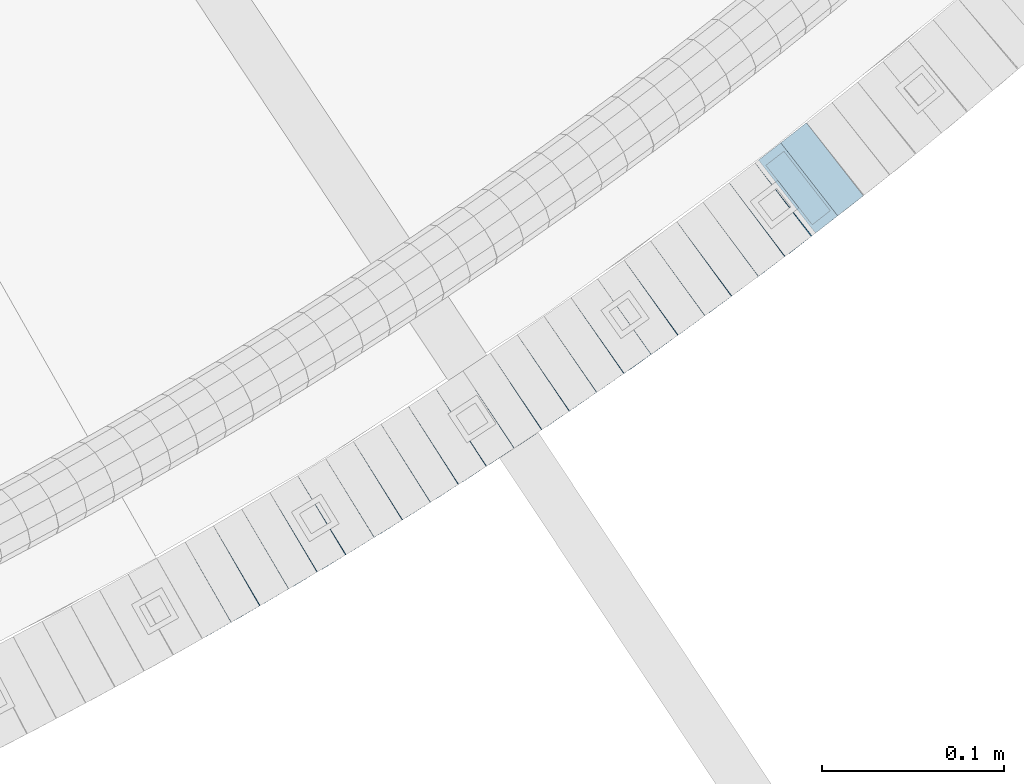
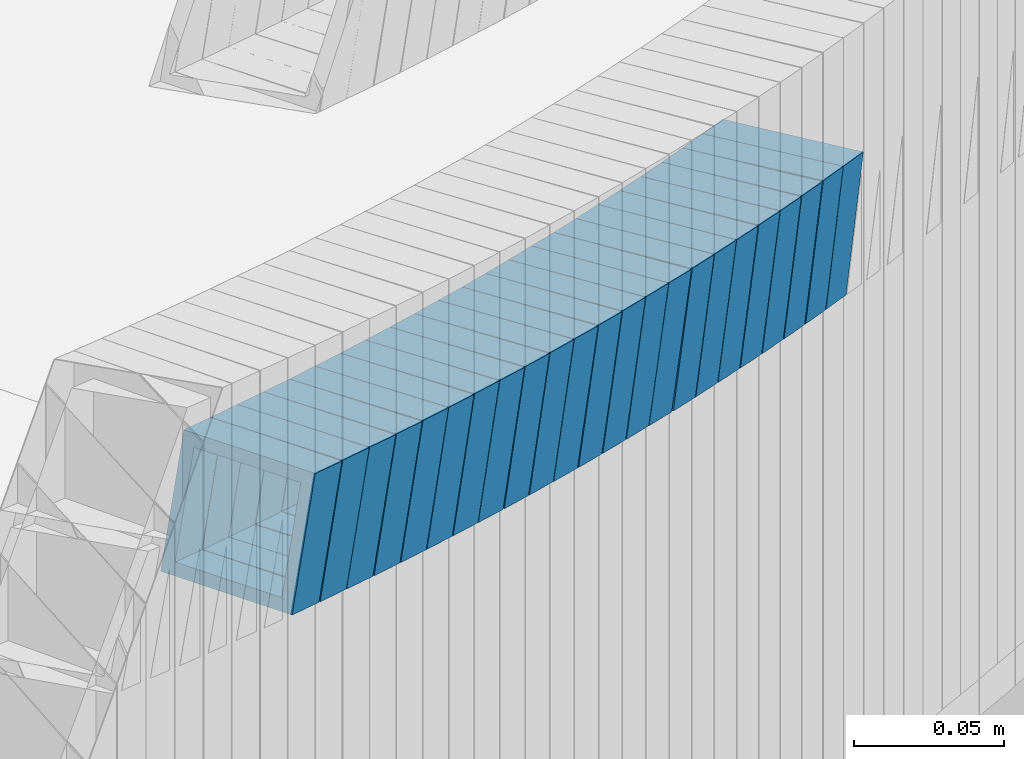
# One storey, part 764 of 975: 23 beams.
"""IFC2X3 building model written with IfcOpenShell, lengths in millimetres."""

from ifc_helpers import new_model, si_unit, frame, origin_with_axes, place, context, subcontext, project, spatial, faceted_brep, material, type_object, element, save


model = new_model("IFC2X3")

# Units and contexts
model_context = context("Model", 3, precision=1e-05, world=origin_with_axes())
body_context = subcontext(model_context, "Body", "Model", "MODEL_VIEW")
ifc_project = project(units=[si_unit("LENGTHUNIT", "METRE", prefix="MILLI"), si_unit("AREAUNIT", "SQUARE_METRE"), si_unit("VOLUMEUNIT", "CUBIC_METRE"), si_unit("MASSUNIT", "GRAM", prefix="KILO"), si_unit("TIMEUNIT", "SECOND"), si_unit("PLANEANGLEUNIT", "RADIAN"), si_unit("SOLIDANGLEUNIT", "STERADIAN"), si_unit("THERMODYNAMICTEMPERATUREUNIT", "DEGREE_CELSIUS"), si_unit("LUMINOUSINTENSITYUNIT", "LUMEN")], contexts=[model_context])

# Site, building, storey
site_placement = place(None, origin_with_axes())
site = spatial("IfcSite", under=ifc_project, at=site_placement, CompositionType="ELEMENT")
building_placement = place(site_placement, origin_with_axes())
building = spatial("IfcBuilding", under=site, at=building_placement, Name="Undefined", CompositionType="ELEMENT")
storey_placement = place(building_placement, origin_with_axes())
storey = spatial("IfcBuildingStorey", under=building, at=storey_placement, Name="Undefined", CompositionType="ELEMENT", Elevation=0.0)

# Beams
ifc_material = material()
beam_type = type_object("IfcBeamType", Name="HSS2X2X.188_TUBES", PredefinedType="NOTDEFINED")
beam_1_placement = place(storey_placement, frame((36158.0204957633, 910.904019125317, 2814.80077400729), z_axis=(-0.497945444032448, 0.867208357182591, -2.00202521227766e-11), x_axis=(0.826211457590163, 0.474405288764676, -0.303832600849288)))
element("IfcBeam", 1, at=beam_1_placement, inside=storey, type_object=beam_type, material=ifc_material, Name="WALL", ObjectType="HSS2X2X.188_TUBES", context=body_context, shape_type="Brep", body=[
    faceted_brep([(0.0, 20.6374999999753, -20.6375000000298), (0.0, -20.6375000000153, -20.6375000000153), (18.7555325170906, -20.6374999999916, -20.6374999999971), (18.7555325171452, 20.637499999988, -20.6374999999571), (0.0, -20.6374999999825, 20.6375000000335), (18.7555325170615, -20.6374999999844, 20.6374999999716), (0.0, 20.6375000000116, 20.6375000000189), (18.7555325171015, 20.6374999999953, 20.637500000008), (0.0, 25.3999999999724, -25.4000000000342), (0.0, 25.400000000016, 25.4000000000196), (18.7555325171015, 25.399999999996, 25.4000000000051), (18.7555325171488, 25.3999999999851, -25.3999999999505), (0.0, -25.399999999976, 25.4000000000378), (18.755532517047, -25.3999999999814, 25.3999999999578), (0.0, -25.400000000016, -25.4000000000196), (18.7555325170979, -25.3999999999924, -25.3999999999978)], [[[0, 1, 2, 3]], [[1, 4, 5, 2]], [[4, 6, 7, 5]], [[6, 0, 3, 7]], [[8, 9, 10, 11]], [[9, 12, 13, 10]], [[12, 14, 15, 13]], [[14, 8, 11, 15]], [[13, 15, 11, 10], [5, 7, 3, 2]], [[14, 12, 9, 8], [6, 4, 1, 0]]]),
])
beam_2_placement = place(storey_placement, frame((36173.8036322131, 919.882520806898, 2809.08831754377), z_axis=(-0.506290523244926, 0.862362978143414, 4.3954059947282e-11), x_axis=(0.822018054827932, 0.482604148898983, -0.302290510936733)))
element("IfcBeam", 2, at=beam_2_placement, inside=storey, type_object=beam_type, material=ifc_material, Name="WALL", ObjectType="HSS2X2X.188_TUBES", context=body_context, shape_type="Brep", body=[
    faceted_brep([(0.0, 20.6374999999753, -20.6375000000298), (0.0, -20.6375000000153, -20.6375000000153), (18.8565638439322, -20.6375000000116, -20.6374999999643), (18.8565638439395, 20.637499999988, -20.6374999999534), (0.0, -20.6374999999825, 20.6375000000335), (18.856563843914, -20.6374999999953, 20.6375000000116), (0.0, 20.6375000000116, 20.6375000000189), (18.8565638439177, 20.6375000000007, 20.6375000000226), (0.0, 25.3999999999724, -25.4000000000342), (0.0, 25.400000000016, 25.4000000000196), (18.8565638439177, 25.4000000000033, 25.4000000000233), (18.8565638439468, 25.3999999999851, -25.3999999999505), (0.0, -25.399999999976, 25.4000000000378), (18.8565638439104, -25.399999999996, 25.4000000000087), (0.0, -25.400000000016, -25.4000000000196), (18.8565638439395, -25.4000000000124, -25.3999999999614)], [[[0, 1, 2, 3]], [[1, 4, 5, 2]], [[4, 6, 7, 5]], [[6, 0, 3, 7]], [[8, 9, 10, 11]], [[9, 12, 13, 10]], [[12, 14, 15, 13]], [[14, 8, 11, 15]], [[13, 15, 11, 10], [5, 7, 3, 2]], [[14, 12, 9, 8], [6, 4, 1, 0]]]),
])
beam_3_placement = place(storey_placement, frame((36189.2422098029, 928.920864783128, 2803.43837842534), z_axis=(-0.508729312158691, 0.860926528195377, 1.20689946925267e-11), x_axis=(0.818952007289953, 0.483926186171334, -0.308436470109202)))
element("IfcBeam", 3, at=beam_3_placement, inside=storey, type_object=beam_type, material=ifc_material, Name="WALL", ObjectType="HSS2X2X.188_TUBES", context=body_context, shape_type="Brep", body=[
    faceted_brep([(0.0, 20.6374999999753, -20.6375000000298), (0.0, -20.6375000000153, -20.6375000000153), (18.8047866246379, -20.6374999999916, -20.6375000000298), (18.8047866247143, 20.6374999999844, -20.6374999999643), (0.0, -20.6374999999825, 20.6375000000335), (18.8047866247107, -20.6375000000189, 20.6375000000407), (0.0, 20.6375000000116, 20.6375000000189), (18.8047866247907, 20.6374999999589, 20.6375000001026), (0.0, 25.3999999999724, -25.4000000000342), (0.0, 25.400000000016, 25.4000000000196), (18.8047866248016, 25.3999999999542, 25.4000000001142), (18.8047866247143, 25.3999999999851, -25.3999999999651), (0.0, -25.399999999976, 25.4000000000378), (18.8047866247107, -25.4000000000196, 25.4000000000415), (0.0, -25.400000000016, -25.4000000000196), (18.8047866246197, -25.3999999999887, -25.4000000000378)], [[[0, 1, 2, 3]], [[1, 4, 5, 2]], [[4, 6, 7, 5]], [[6, 0, 3, 7]], [[8, 9, 10, 11]], [[9, 12, 13, 10]], [[12, 14, 15, 13]], [[14, 8, 11, 15]], [[13, 15, 11, 10], [5, 7, 3, 2]], [[14, 12, 9, 8], [6, 4, 1, 0]]]),
])
beam_4_placement = place(storey_placement, frame((36204.9337150417, 938.125144227644, 2797.60333183494), z_axis=(-0.515319238450917, 0.856998297829329, 1.51460426423e-10), x_axis=(0.816397773087495, 0.490905851052606, -0.304148190032584)))
element("IfcBeam", 4, at=beam_4_placement, inside=storey, type_object=beam_type, material=ifc_material, Name="WALL", ObjectType="HSS2X2X.188_TUBES", context=body_context, shape_type="Brep", body=[
    faceted_brep([(0.0, 20.6374999999753, -20.6375000000298), (0.0, -20.6375000000153, -20.6375000000153), (18.7416648140024, -20.6375000000153, -20.6374999999825), (18.7416648139188, 20.6375000000189, -20.6375000000298), (0.0, -20.6374999999825, 20.6375000000335), (18.7416648140097, -20.6375000000189, 20.6375000000226), (0.0, 20.6375000000116, 20.6375000000189), (18.741664813926, 20.6375000000153, 20.6374999999753), (0.0, 25.3999999999724, -25.4000000000342), (0.0, 25.400000000016, 25.4000000000196), (18.7416648139224, 25.4000000000196, 25.3999999999687), (18.7416648139042, 25.4000000000233, -25.4000000000378), (0.0, -25.399999999976, 25.4000000000378), (18.7416648140133, -25.4000000000215, 25.4000000000269), (0.0, -25.400000000016, -25.4000000000196), (18.7416648140133, -25.4000000000196, -25.399999999976)], [[[0, 1, 2, 3]], [[1, 4, 5, 2]], [[4, 6, 7, 5]], [[6, 0, 3, 7]], [[8, 9, 10, 11]], [[9, 12, 13, 10]], [[12, 14, 15, 13]], [[14, 8, 11, 15]], [[13, 15, 11, 10], [5, 7, 3, 2]], [[14, 12, 9, 8], [6, 4, 1, 0]]]),
])
beam_5_placement = place(storey_placement, frame((36220.4096730901, 947.345347035379, 2791.92953429297), z_axis=(-0.52347586495318, 0.852040503034639, -1.87415025720839e-11), x_axis=(0.810795896241692, 0.498136041148497, -0.307360536091628)))
element("IfcBeam", 5, at=beam_5_placement, inside=storey, type_object=beam_type, material=ifc_material, Name="WALL", ObjectType="HSS2X2X.188_TUBES", context=body_context, shape_type="Brep", body=[
    faceted_brep([(0.0, 20.6374999999753, -20.6375000000298), (0.0, -20.6375000000153, -20.6375000000153), (18.8653120832787, -20.6374999999989, -20.6374999999935), (18.8653120832823, 20.6374999999971, -20.6374999999935), (0.0, -20.6374999999825, 20.6375000000335), (18.8653120833151, -20.6375000000116, 20.6375000000298), (0.0, 20.6375000000116, 20.6375000000189), (18.8653120833151, 20.6374999999844, 20.6375000000298), (0.0, 25.3999999999724, -25.4000000000342), (0.0, 25.400000000016, 25.4000000000196), (18.8653120833187, 25.3999999999814, 25.4000000000378), (18.8653120832823, 25.3999999999942, -25.3999999999905), (0.0, -25.399999999976, 25.4000000000378), (18.8653120833187, -25.4000000000124, 25.4000000000342), (0.0, -25.400000000016, -25.4000000000196), (18.8653120832787, -25.3999999999978, -25.3999999999942)], [[[0, 1, 2, 3]], [[1, 4, 5, 2]], [[4, 6, 7, 5]], [[6, 0, 3, 7]], [[8, 9, 10, 11]], [[9, 12, 13, 10]], [[12, 14, 15, 13]], [[14, 8, 11, 15]], [[13, 15, 11, 10], [5, 7, 3, 2]], [[14, 12, 9, 8], [6, 4, 1, 0]]]),
])
beam_6_placement = place(storey_placement, frame((36235.8606590076, 956.811705255529, 2786.10098382923), z_axis=(-0.525969301855889, 0.850503552905706, -2.32735146710183e-11), x_axis=(0.810289340111615, 0.501099986069019, -0.303858502041842)))
element("IfcBeam", 6, at=beam_6_placement, inside=storey, type_object=beam_type, material=ifc_material, Name="WALL", ObjectType="HSS2X2X.188_TUBES", context=body_context, shape_type="Brep", body=[
    faceted_brep([(0.0, 20.6374999999753, -20.6375000000298), (0.0, -20.6375000000153, -20.6375000000153), (18.7555325170906, -20.6374999999916, -20.6374999999971), (18.7555325171452, 20.637499999988, -20.6374999999571), (0.0, -20.6374999999825, 20.6375000000335), (18.7555325170615, -20.6374999999844, 20.6374999999716), (0.0, 20.6375000000116, 20.6375000000189), (18.7555325171015, 20.6374999999953, 20.637500000008), (0.0, 25.3999999999724, -25.4000000000342), (0.0, 25.400000000016, 25.4000000000196), (18.7555325171015, 25.399999999996, 25.4000000000051), (18.7555325171488, 25.3999999999851, -25.3999999999505), (0.0, -25.399999999976, 25.4000000000378), (18.755532517047, -25.3999999999814, 25.3999999999578), (0.0, -25.400000000016, -25.4000000000196), (18.7555325170979, -25.3999999999924, -25.3999999999978)], [[[0, 1, 2, 3]], [[1, 4, 5, 2]], [[4, 6, 7, 5]], [[6, 0, 3, 7]], [[8, 9, 10, 11]], [[9, 12, 13, 10]], [[12, 14, 15, 13]], [[14, 8, 11, 15]], [[13, 15, 11, 10], [5, 7, 3, 2]], [[14, 12, 9, 8], [6, 4, 1, 0]]]),
])
beam_7_placement = place(storey_placement, frame((36251.2478517772, 966.258227144704, 2780.40498443343), z_axis=(-0.532515895694051, 0.846420002618772, -1.7875663615996e-11), x_axis=(0.806265556906498, 0.507253164941173, -0.304351898964699)))
element("IfcBeam", 7, at=beam_7_placement, inside=storey, type_object=beam_type, material=ifc_material, Name="WALL", ObjectType="HSS2X2X.188_TUBES", context=body_context, shape_type="Brep", body=[
    faceted_brep([(0.0, 20.6374999999753, -20.6375000000298), (0.0, -20.6375000000153, -20.6375000000153), (18.7347271129966, -20.6375000000116, -20.6375000000262), (18.7347271130257, 20.6374999999989, -20.6374999999935), (0.0, -20.6374999999825, 20.6375000000335), (18.7347271129947, -20.6375000000116, 20.6374999999607), (0.0, 20.6375000000116, 20.6375000000189), (18.7347271130147, 20.6375000000007, 20.6374999999898), (0.0, 25.3999999999724, -25.4000000000342), (0.0, 25.400000000016, 25.4000000000196), (18.7347271130166, 25.4000000000015, 25.3999999999905), (18.7347271130257, 25.3999999999996, -25.3999999999869), (0.0, -25.399999999976, 25.4000000000378), (18.7347271129875, -25.4000000000106, 25.3999999999505), (0.0, -25.400000000016, -25.4000000000196), (18.7347271130002, -25.4000000000124, -25.4000000000233)], [[[0, 1, 2, 3]], [[1, 4, 5, 2]], [[4, 6, 7, 5]], [[6, 0, 3, 7]], [[8, 9, 10, 11]], [[9, 12, 13, 10]], [[12, 14, 15, 13]], [[14, 8, 11, 15]], [[13, 15, 11, 10], [5, 7, 3, 2]], [[14, 12, 9, 8], [6, 4, 1, 0]]]),
])
beam_8_placement = place(storey_placement, frame((36266.3832622508, 975.737070016621, 2774.73766047195), z_axis=(-0.536513822259892, 0.843891532440089, 1.68464794114698e-10), x_axis=(0.802771407025919, 0.510371226016481, -0.308349282009963)))
element("IfcBeam", 8, at=beam_8_placement, inside=storey, type_object=beam_type, material=ifc_material, Name="WALL", ObjectType="HSS2X2X.188_TUBES", context=body_context, shape_type="Brep", body=[
    faceted_brep([(0.0, 20.6374999999753, -20.6375000000298), (0.0, -20.6375000000153, -20.6375000000153), (18.8066477608099, -20.6374999999862, -20.6375000000116), (18.8066477608172, 20.6375000000062, -20.6374999999971), (0.0, -20.6374999999825, 20.6375000000335), (18.8066477608463, -20.6375000000062, 20.6375000000407), (0.0, 20.6375000000116, 20.6375000000189), (18.8066477608536, 20.6374999999844, 20.637500000048), (0.0, 25.3999999999724, -25.4000000000342), (0.0, 25.400000000016, 25.4000000000196), (18.8066477608591, 25.3999999999814, 25.400000000056), (18.8066477608154, 25.4000000000051, -25.4000000000015), (0.0, -25.399999999976, 25.4000000000378), (18.8066477608518, -25.4000000000087, 25.4000000000451), (0.0, -25.400000000016, -25.4000000000196), (18.8066477608081, -25.3999999999851, -25.4000000000196)], [[[0, 1, 2, 3]], [[1, 4, 5, 2]], [[4, 6, 7, 5]], [[6, 0, 3, 7]], [[8, 9, 10, 11]], [[9, 12, 13, 10]], [[12, 14, 15, 13]], [[14, 8, 11, 15]], [[13, 15, 11, 10], [5, 7, 3, 2]], [[14, 12, 9, 8], [6, 4, 1, 0]]]),
])
beam_9_placement = place(storey_placement, frame((36281.7740933225, 985.452161368245, 2768.90206907921), z_axis=(-0.543019139473726, 0.839720319014143, -1.43465058499714e-10), x_axis=(0.799980089763614, 0.517320457847134, -0.303992433910174)))
element("IfcBeam", 9, at=beam_9_placement, inside=storey, type_object=beam_type, material=ifc_material, Name="WALL", ObjectType="HSS2X2X.188_TUBES", context=body_context, shape_type="Brep", body=[
    faceted_brep([(0.0, 20.6374999999753, -20.6375000000298), (0.0, -20.6375000000153, -20.6375000000153), (18.7547327359644, -20.6374999999844, -20.6375000000553), (18.7547327359898, 20.6375000000171, -20.6375000000335), (0.0, -20.6374999999825, 20.6375000000335), (18.7547327360044, -20.6374999999953, 20.6374999999898), (0.0, 20.6375000000116, 20.6375000000189), (18.7547327360262, 20.6375000000062, 20.6375000000116), (0.0, 25.3999999999724, -25.4000000000342), (0.0, 25.400000000016, 25.4000000000196), (18.7547327360371, 25.4000000000033, 25.4000000000124), (18.7547327359898, 25.4000000000178, -25.4000000000342), (0.0, -25.399999999976, 25.4000000000378), (18.7547327360044, -25.399999999996, 25.3999999999869), (0.0, -25.400000000016, -25.4000000000196), (18.7547327359498, -25.3999999999814, -25.4000000000597)], [[[0, 1, 2, 3]], [[1, 4, 5, 2]], [[4, 6, 7, 5]], [[6, 0, 3, 7]], [[8, 9, 10, 11]], [[9, 12, 13, 10]], [[12, 14, 15, 13]], [[14, 8, 11, 15]], [[13, 15, 11, 10], [5, 7, 3, 2]], [[14, 12, 9, 8], [6, 4, 1, 0]]]),
])
beam_10_placement = place(storey_placement, frame((36296.9621916554, 995.203307564994, 2763.20572429746), z_axis=(-0.549513511668024, 0.835484829601517, -1.94294898392399e-10), x_axis=(0.795824815810987, 0.523428401875683, -0.304443049927694)))
element("IfcBeam", 10, at=beam_10_placement, inside=storey, type_object=beam_type, material=ifc_material, Name="WALL", ObjectType="HSS2X2X.188_TUBES", context=body_context, shape_type="Brep", body=[
    faceted_brep([(0.0, 20.6374999999753, -20.6375000000298), (0.0, -20.6375000000153, -20.6375000000153), (18.724849799155, -20.6375000000171, -20.6374999999425), (18.7248497991204, 20.6374999999989, -20.6375000000007), (0.0, -20.6374999999825, 20.6375000000335), (18.7248497991168, -20.6374999999953, 20.6375000000007), (0.0, 20.6375000000116, 20.6375000000189), (18.724849799084, 20.6375000000226, 20.6374999999498), (0.0, 25.3999999999724, -25.4000000000342), (0.0, 25.400000000016, 25.4000000000196), (18.7248497990731, 25.4000000000269, 25.399999999936), (18.7248497991204, 25.3999999999978, -25.3999999999978), (0.0, -25.399999999976, 25.4000000000378), (18.7248497991186, -25.3999999999942, 25.4000000000051), (0.0, -25.400000000016, -25.4000000000196), (18.7248497991604, -25.4000000000233, -25.3999999999323)], [[[0, 1, 2, 3]], [[1, 4, 5, 2]], [[4, 6, 7, 5]], [[6, 0, 3, 7]], [[8, 9, 10, 11]], [[9, 12, 13, 10]], [[12, 14, 15, 13]], [[14, 8, 11, 15]], [[13, 15, 11, 10], [5, 7, 3, 2]], [[14, 12, 9, 8], [6, 4, 1, 0]]]),
])
beam_11_placement = place(storey_placement, frame((36311.897043674, 1004.98277140561, 2757.53819885886), z_axis=(-0.553409530714104, 0.832909293569711, 0.0), x_axis=(0.792306643130986, 0.526431930087033, -0.308414666050999)))
element("IfcBeam", 11, at=beam_11_placement, inside=storey, type_object=beam_type, material=ifc_material, Name="WALL", ObjectType="HSS2X2X.188_TUBES", context=body_context, shape_type="Brep", body=[
    faceted_brep([(0.0, 20.6374999999753, -20.6375000000298), (0.0, -20.6375000000153, -20.6375000000153), (18.8066477608099, -20.6374999999862, -20.6375000000116), (18.8066477608172, 20.6375000000062, -20.6374999999971), (0.0, -20.6374999999825, 20.6375000000335), (18.8066477608463, -20.6375000000062, 20.6375000000407), (0.0, 20.6375000000116, 20.6375000000189), (18.8066477608536, 20.6374999999844, 20.637500000048), (0.0, 25.3999999999724, -25.4000000000342), (0.0, 25.400000000016, 25.4000000000196), (18.8066477608591, 25.3999999999814, 25.400000000056), (18.8066477608154, 25.4000000000051, -25.4000000000015), (0.0, -25.399999999976, 25.4000000000378), (18.8066477608518, -25.4000000000087, 25.4000000000451), (0.0, -25.400000000016, -25.4000000000196), (18.8066477608081, -25.3999999999851, -25.4000000000196)], [[[0, 1, 2, 3]], [[1, 4, 5, 2]], [[4, 6, 7, 5]], [[6, 0, 3, 7]], [[8, 9, 10, 11]], [[9, 12, 13, 10]], [[12, 14, 15, 13]], [[14, 8, 11, 15]], [[13, 15, 11, 10], [5, 7, 3, 2]], [[14, 12, 9, 8], [6, 4, 1, 0]]]),
])
beam_12_placement = place(storey_placement, frame((36327.0872801327, 1015.004575079, 2751.70224430335), z_axis=(-0.559857410943981, 0.8285889689171, 0.0), x_axis=(0.789369820595938, 0.533357986726988, -0.304014052844389)))
element("IfcBeam", 12, at=beam_12_placement, inside=storey, type_object=beam_type, material=ifc_material, Name="WALL", ObjectType="HSS2X2X.188_TUBES", context=body_context, shape_type="Brep", body=[
    faceted_brep([(0.0, 20.6374999999753, -20.6375000000298), (0.0, -20.6375000000153, -20.6375000000153), (18.7547327359644, -20.6374999999844, -20.6375000000553), (18.7547327359898, 20.6375000000171, -20.6375000000335), (0.0, -20.6374999999825, 20.6375000000335), (18.7547327360044, -20.6374999999953, 20.6374999999898), (0.0, 20.6375000000116, 20.6375000000189), (18.7547327360262, 20.6375000000062, 20.6375000000116), (0.0, 25.3999999999724, -25.4000000000342), (0.0, 25.400000000016, 25.4000000000196), (18.7547327360371, 25.4000000000033, 25.4000000000124), (18.7547327359898, 25.4000000000178, -25.4000000000342), (0.0, -25.399999999976, 25.4000000000378), (18.7547327360044, -25.399999999996, 25.3999999999869), (0.0, -25.400000000016, -25.4000000000196), (18.7547327359498, -25.3999999999814, -25.4000000000597)], [[[0, 1, 2, 3]], [[1, 4, 5, 2]], [[4, 6, 7, 5]], [[6, 0, 3, 7]], [[8, 9, 10, 11]], [[9, 12, 13, 10]], [[12, 14, 15, 13]], [[14, 8, 11, 15]], [[13, 15, 11, 10], [5, 7, 3, 2]], [[14, 12, 9, 8], [6, 4, 1, 0]]]),
])
beam_13_placement = place(storey_placement, frame((36342.0760118863, 1025.06037855151, 2746.00554805691), z_axis=(-0.566290843295719, 0.824205484572521, 1.55258931044955e-10), x_axis=(0.785086613936173, 0.539413251956151, -0.304421339975247)))
element("IfcBeam", 13, at=beam_13_placement, inside=storey, type_object=beam_type, material=ifc_material, Name="WALL", ObjectType="HSS2X2X.188_TUBES", context=body_context, shape_type="Brep", body=[
    faceted_brep([(0.0, 20.6374999999753, -20.6375000000298), (0.0, -20.6375000000153, -20.6375000000153), (18.724849799155, -20.6375000000171, -20.6374999999425), (18.7248497991204, 20.6374999999989, -20.6375000000007), (0.0, -20.6374999999825, 20.6375000000335), (18.7248497991168, -20.6374999999953, 20.6375000000007), (0.0, 20.6375000000116, 20.6375000000189), (18.724849799084, 20.6375000000226, 20.6374999999498), (0.0, 25.3999999999724, -25.4000000000342), (0.0, 25.400000000016, 25.4000000000196), (18.7248497990731, 25.4000000000269, 25.399999999936), (18.7248497991204, 25.3999999999978, -25.3999999999978), (0.0, -25.399999999976, 25.4000000000378), (18.7248497991186, -25.3999999999942, 25.4000000000051), (0.0, -25.400000000016, -25.4000000000196), (18.7248497991604, -25.4000000000233, -25.3999999999323)], [[[0, 1, 2, 3]], [[1, 4, 5, 2]], [[4, 6, 7, 5]], [[6, 0, 3, 7]], [[8, 9, 10, 11]], [[9, 12, 13, 10]], [[12, 14, 15, 13]], [[14, 8, 11, 15]], [[13, 15, 11, 10], [5, 7, 3, 2]], [[14, 12, 9, 8], [6, 4, 1, 0]]]),
])
beam_14_placement = place(storey_placement, frame((36356.9108466319, 1035.21025555686, 2740.29843596918), z_axis=(-0.570081547875678, 0.821588113820832, 0.0), x_axis=(0.782823517351627, 0.543183665243979, -0.303543813136332)))
element("IfcBeam", 14, at=beam_14_placement, inside=storey, type_object=beam_type, material=ifc_material, Name="WALL", ObjectType="HSS2X2X.188_TUBES", context=body_context, shape_type="Brep", body=[
    faceted_brep([(0.0, 20.6374999999753, -20.6375000000298), (0.0, -20.6375000000153, -20.6375000000153), (18.7771137292038, -20.637500000008, -20.6374999999862), (18.777113729182, 20.6375000000062, -20.6375000000189), (0.0, -20.6374999999825, 20.6375000000335), (18.7771137291729, -20.6374999999916, 20.6374999999753), (0.0, 20.6375000000116, 20.6375000000189), (18.7771137291529, 20.6375000000207, 20.6374999999389), (0.0, 25.3999999999724, -25.4000000000342), (0.0, 25.400000000016, 25.4000000000196), (18.7771137291475, 25.4000000000251, 25.3999999999287), (18.7771137291857, 25.4000000000051, -25.4000000000196), (0.0, -25.399999999976, 25.4000000000378), (18.7771137291711, -25.3999999999905, 25.3999999999724), (0.0, -25.400000000016, -25.4000000000196), (18.7771137292129, -25.4000000000124, -25.3999999999724)], [[[0, 1, 2, 3]], [[1, 4, 5, 2]], [[4, 6, 7, 5]], [[6, 0, 3, 7]], [[8, 9, 10, 11]], [[9, 12, 13, 10]], [[12, 14, 15, 13]], [[14, 8, 11, 15]], [[13, 15, 11, 10], [5, 7, 3, 2]], [[14, 12, 9, 8], [6, 4, 1, 0]]]),
])
for number, where, z_axis, x_axis, name in (
    (15, (36371.5644937637, 1045.34760827454, 2734.64840848756), (-0.572708438875059, 0.819759137821161, 0.0), (0.77946802537301, 0.544559853260598, -0.309651681148185), "WALL"),
    (16, (36386.5885859147, 1055.72938590516, 2728.80445651513), (-0.582827439183217, 0.812595948879351, 7.00201781000943e-11), (0.774063016666053, 0.555190025760518, -0.304286840868751), "WALL"),
):
    element("IfcBeam", number, at=place(storey_placement, frame(where, z_axis=z_axis, x_axis=x_axis)), inside=storey, type_object=beam_type, material=ifc_material, Name=name, ObjectType="HSS2X2X.188_TUBES", context=body_context, shape_type="Brep", body=[
        faceted_brep([(0.0, 20.6374999999753, -20.6375000000298), (0.0, -20.6375000000153, -20.6375000000153), (18.7347271129966, -20.6375000000116, -20.6375000000262), (18.7347271130257, 20.6374999999989, -20.6374999999935), (0.0, -20.6374999999825, 20.6375000000335), (18.7347271129947, -20.6375000000116, 20.6374999999607), (0.0, 20.6375000000116, 20.6375000000189), (18.7347271130147, 20.6375000000007, 20.6374999999898), (0.0, 25.3999999999724, -25.4000000000342), (0.0, 25.400000000016, 25.4000000000196), (18.7347271130166, 25.4000000000015, 25.3999999999905), (18.7347271130257, 25.3999999999996, -25.3999999999869), (0.0, -25.399999999976, 25.4000000000378), (18.7347271129875, -25.4000000000106, 25.3999999999505), (0.0, -25.400000000016, -25.4000000000196), (18.7347271130002, -25.4000000000124, -25.4000000000233)], [[[0, 1, 2, 3]], [[1, 4, 5, 2]], [[4, 6, 7, 5]], [[6, 0, 3, 7]], [[8, 9, 10, 11]], [[9, 12, 13, 10]], [[12, 14, 15, 13]], [[14, 8, 11, 15]], [[13, 15, 11, 10], [5, 7, 3, 2]], [[14, 12, 9, 8], [6, 4, 1, 0]]]),
    ])
beam_15_placement = place(storey_placement, frame((36401.2211889346, 1066.18177220305, 2723.0971487143), z_axis=(-0.58650981199336, 0.809942121657784, 6.21935214439872e-11), x_axis=(0.771768059992756, 0.558866525994744, -0.303384685997142)))
element("IfcBeam", 17, at=beam_15_placement, inside=storey, type_object=beam_type, material=ifc_material, Name="WALL", ObjectType="HSS2X2X.188_TUBES", context=body_context, shape_type="Brep", body=[
    faceted_brep([(0.0, 20.6374999999753, -20.6375000000298), (0.0, -20.6375000000153, -20.6375000000153), (18.7853666454903, -20.6375000000535, -20.6375000000326), (18.785366645363, 20.6374999999862, -20.6375000000044), (0.0, -20.6374999999825, 20.6375000000335), (18.785366645352, -20.6375000000007, 20.6374999999989), (0.0, 20.6375000000116, 20.6375000000189), (18.7853666453102, 20.6375000000025, 20.6374999999753), (0.0, 25.3999999999724, -25.4000000000342), (0.0, 25.400000000016, 25.4000000000196), (18.7853666452065, 25.4000000000451, 25.4000000000351), (18.7853666453739, 25.3999999999833, -25.400000000006), (0.0, -25.399999999976, 25.4000000000378), (18.7853666497213, -25.399999993424, 25.3999999995158), (0.0, -25.400000000016, -25.4000000000196), (18.7853666455194, -25.4000000000633, -25.4000000000406)], [[[0, 1, 2, 3]], [[1, 4, 5, 2]], [[4, 6, 7, 5]], [[6, 0, 3, 7]], [[8, 9, 10, 11]], [[9, 12, 13, 10]], [[12, 14, 15, 13]], [[14, 8, 11, 15]], [[13, 15, 11, 10], [5, 7, 3, 2]], [[14, 12, 9, 8], [6, 4, 1, 0]]]),
])
beam_16_placement = place(storey_placement, frame((36415.7780740916, 1076.69169442673, 2717.40727744047), z_axis=(-0.589172157703833, 0.808007530030884, 1.76071807800326e-10), x_axis=(0.769602441062318, 0.561168447045449, -0.304634300024668)))
element("IfcBeam", 18, at=beam_16_placement, inside=storey, type_object=beam_type, material=ifc_material, Name="WALL", ObjectType="HSS2X2X.188_TUBES", context=body_context, shape_type="Brep", body=[
    faceted_brep([(0.0, 20.6374999999753, -20.6375000000298), (0.0, -20.6375000000153, -20.6375000000153), (18.7112265765609, -20.6375000000062, -20.6374999999862), (18.7112265765645, 20.6374999999898, -20.6374999999789), (0.0, -20.6374999999825, 20.6375000000335), (18.7112265765209, -20.6374999999916, 20.6374999999607), (0.0, 20.6375000000116, 20.6375000000189), (18.7112265765245, 20.6375000000025, 20.6374999999716), (0.0, 25.3999999999724, -25.4000000000342), (0.0, 25.400000000016, 25.4000000000196), (18.7112265765172, 25.4000000000051, 25.3999999999614), (18.7112265765718, 25.3999999999887, -25.3999999999724), (0.0, -25.399999999976, 25.4000000000378), (18.7112265765136, -25.3999999999905, 25.3999999999542), (0.0, -25.400000000016, -25.4000000000196), (18.7112265765682, -25.4000000000069, -25.3999999999796)], [[[0, 1, 2, 3]], [[1, 4, 5, 2]], [[4, 6, 7, 5]], [[6, 0, 3, 7]], [[8, 9, 10, 11]], [[9, 12, 13, 10]], [[12, 14, 15, 13]], [[14, 8, 11, 15]], [[13, 15, 11, 10], [5, 7, 3, 2]], [[14, 12, 9, 8], [6, 4, 1, 0]]]),
])
beam_17_placement = place(storey_placement, frame((36430.3427884604, 1087.2259673801, 2711.7316623909), z_axis=(-0.596426622612919, 0.802667604826897, -6.70688677928411e-11), x_axis=(0.763745734904336, 0.567505510928924, -0.307619809961479)))
element("IfcBeam", 19, at=beam_17_placement, inside=storey, type_object=beam_type, material=ifc_material, Name="WALL", ObjectType="HSS2X2X.188_TUBES", context=body_context, shape_type="Brep", body=[
    faceted_brep([(0.0, 20.6374999999753, -20.6375000000298), (0.0, -20.6375000000153, -20.6375000000153), (18.8480768248774, -20.6374999999716, -20.6375000000735), (18.8480768249356, 20.6375000000153, -20.6375000000226), (0.0, -20.6374999999825, 20.6375000000335), (18.8480768249283, -20.6374999999935, 20.6374999999716), (0.0, 20.6375000000116, 20.6375000000189), (18.8480768249865, 20.6374999999935, 20.6375000000262), (0.0, 25.3999999999724, -25.4000000000342), (0.0, 25.400000000016, 25.4000000000196), (18.848076825001, 25.3999999999887, 25.4000000000378), (18.8480768249392, 25.4000000000142, -25.4000000000233), (0.0, -25.399999999976, 25.4000000000378), (18.8480768249283, -25.399999999996, 25.3999999999833), (0.0, -25.400000000016, -25.4000000000196), (18.8480768248664, -25.3999999999687, -25.4000000000779)], [[[0, 1, 2, 3]], [[1, 4, 5, 2]], [[4, 6, 7, 5]], [[6, 0, 3, 7]], [[8, 9, 10, 11]], [[9, 12, 13, 10]], [[12, 14, 15, 13]], [[14, 8, 11, 15]], [[13, 15, 11, 10], [5, 7, 3, 2]], [[14, 12, 9, 8], [6, 4, 1, 0]]]),
])
beam_18_placement = place(storey_placement, frame((36444.8991882116, 1098.01022803086, 2705.9024546398), z_axis=(-0.599103767601802, 0.800671390550034, -2.06921413337113e-10), x_axis=(0.762767019599652, 0.570741755700437, -0.304040000840428)))
element("IfcBeam", 20, at=beam_18_placement, inside=storey, type_object=beam_type, material=ifc_material, Name="WALL", ObjectType="HSS2X2X.188_TUBES", context=body_context, shape_type="Brep", body=[
    faceted_brep([(0.0, 20.6374999999753, -20.6375000000298), (0.0, -20.6375000000153, -20.6375000000153), (18.7547327359644, -20.6374999999844, -20.6375000000553), (18.7547327359898, 20.6375000000171, -20.6375000000335), (0.0, -20.6374999999825, 20.6375000000335), (18.7547327360044, -20.6374999999953, 20.6374999999898), (0.0, 20.6375000000116, 20.6375000000189), (18.7547327360262, 20.6375000000062, 20.6375000000116), (0.0, 25.3999999999724, -25.4000000000342), (0.0, 25.400000000016, 25.4000000000196), (18.7547327360371, 25.4000000000033, 25.4000000000124), (18.7547327359898, 25.4000000000178, -25.4000000000342), (0.0, -25.399999999976, 25.4000000000378), (18.7547327360044, -25.399999999996, 25.3999999999869), (0.0, -25.400000000016, -25.4000000000196), (18.7547327359498, -25.3999999999814, -25.4000000000597)], [[[0, 1, 2, 3]], [[1, 4, 5, 2]], [[4, 6, 7, 5]], [[6, 0, 3, 7]], [[8, 9, 10, 11]], [[9, 12, 13, 10]], [[12, 14, 15, 13]], [[14, 8, 11, 15]], [[13, 15, 11, 10], [5, 7, 3, 2]], [[14, 12, 9, 8], [6, 4, 1, 0]]]),
])
beam_19_placement = place(storey_placement, frame((36459.3886474955, 1108.77721530749, 2700.20491401757), z_axis=(-0.605367471213059, 0.795946119280134, 0.0), x_axis=(0.75818837790351, 0.576650315926618, -0.304343221961284)))
element("IfcBeam", 21, at=beam_19_placement, inside=storey, type_object=beam_type, material=ifc_material, Name="WALL", ObjectType="HSS2X2X.188_TUBES", context=body_context, shape_type="Brep", body=[
    faceted_brep([(0.0, 20.6374999999753, -20.6375000000298), (0.0, -20.6375000000153, -20.6375000000153), (18.7347271129966, -20.6375000000116, -20.6375000000262), (18.7347271130257, 20.6374999999989, -20.6374999999935), (0.0, -20.6374999999825, 20.6375000000335), (18.7347271129947, -20.6375000000116, 20.6374999999607), (0.0, 20.6375000000116, 20.6375000000189), (18.7347271130147, 20.6375000000007, 20.6374999999898), (0.0, 25.3999999999724, -25.4000000000342), (0.0, 25.400000000016, 25.4000000000196), (18.7347271130166, 25.4000000000015, 25.3999999999905), (18.7347271130257, 25.3999999999996, -25.3999999999869), (0.0, -25.399999999976, 25.4000000000378), (18.7347271129875, -25.4000000000106, 25.3999999999505), (0.0, -25.400000000016, -25.4000000000196), (18.7347271130002, -25.4000000000124, -25.4000000000233)], [[[0, 1, 2, 3]], [[1, 4, 5, 2]], [[4, 6, 7, 5]], [[6, 0, 3, 7]], [[8, 9, 10, 11]], [[9, 12, 13, 10]], [[12, 14, 15, 13]], [[14, 8, 11, 15]], [[13, 15, 11, 10], [5, 7, 3, 2]], [[14, 12, 9, 8], [6, 4, 1, 0]]]),
])
beam_20_placement = place(storey_placement, frame((36473.8104781212, 1119.62737826532, 2694.53895338844), z_axis=(-0.615101329334371, 0.78844806718711, 4.81768438476138e-11), x_axis=(0.749989390054478, 0.585098106042497, -0.308506274022417)))
element("IfcBeam", 22, at=beam_20_placement, inside=storey, type_object=beam_type, material=ifc_material, Name="WALL", ObjectType="HSS2X2X.188_TUBES", context=body_context, shape_type="Brep", body=[
    faceted_brep([(0.0, 20.6374999999753, -20.6375000000298), (0.0, -20.6375000000153, -20.6375000000153), (18.8047866246379, -20.6374999999916, -20.6375000000298), (18.8047866247143, 20.6374999999844, -20.6374999999643), (0.0, -20.6374999999825, 20.6375000000335), (18.8047866247107, -20.6375000000189, 20.6375000000407), (0.0, 20.6375000000116, 20.6375000000189), (18.8047866247907, 20.6374999999589, 20.6375000001026), (0.0, 25.3999999999724, -25.4000000000342), (0.0, 25.400000000016, 25.4000000000196), (18.8047866248016, 25.3999999999542, 25.4000000001142), (18.8047866247143, 25.3999999999851, -25.3999999999651), (0.0, -25.399999999976, 25.4000000000378), (18.8047866247107, -25.4000000000196, 25.4000000000415), (0.0, -25.400000000016, -25.4000000000196), (18.8047866246197, -25.3999999999887, -25.4000000000378)], [[[0, 1, 2, 3]], [[1, 4, 5, 2]], [[4, 6, 7, 5]], [[6, 0, 3, 7]], [[8, 9, 10, 11]], [[9, 12, 13, 10]], [[12, 14, 15, 13]], [[14, 8, 11, 15]], [[13, 15, 11, 10], [5, 7, 3, 2]], [[14, 12, 9, 8], [6, 4, 1, 0]]]),
])
beam_21_placement = place(storey_placement, frame((36488.0070990727, 1130.70275631255, 2688.69955150653), z_axis=(-0.615101329334371, 0.78844806718711, 4.81768438476138e-11), x_axis=(0.751212474107942, 0.586052285084192, -0.303681639043623)))
element("IfcBeam", 23, at=beam_21_placement, inside=storey, type_object=beam_type, material=ifc_material, Name="WALL", ObjectType="HSS2X2X.188_TUBES", context=body_context, shape_type="Brep", body=[
    faceted_brep([(0.0, 20.6374999999753, -20.6375000000298), (0.0, -20.6375000000153, -20.6375000000153), (18.767258723612, -20.6375000000025, -20.6374999999862), (18.7672587236229, 20.6374999999953, -20.637499999968), (0.0, -20.6374999999825, 20.6375000000335), (18.767258723612, -20.6375000000135, 20.6375000000153), (0.0, 20.6375000000116, 20.6375000000189), (18.7672587236266, 20.6374999999844, 20.6375000000371), (0.0, 25.3999999999724, -25.4000000000342), (0.0, 25.400000000016, 25.4000000000196), (18.7672587236302, 25.3999999999814, 25.4000000000342), (18.7672587236229, 25.399999999996, -25.3999999999687), (0.0, -25.399999999976, 25.4000000000378), (18.7672587236157, -25.4000000000142, 25.400000000016), (0.0, -25.400000000016, -25.4000000000196), (18.767258723612, -25.4000000000015, -25.3999999999905)], [[[0, 1, 2, 3]], [[1, 4, 5, 2]], [[4, 6, 7, 5]], [[6, 0, 3, 7]], [[8, 9, 10, 11]], [[9, 12, 13, 10]], [[12, 14, 15, 13]], [[14, 8, 11, 15]], [[13, 15, 11, 10], [5, 7, 3, 2]], [[14, 12, 9, 8], [6, 4, 1, 0]]]),
])

save(model, "model.ifc")
